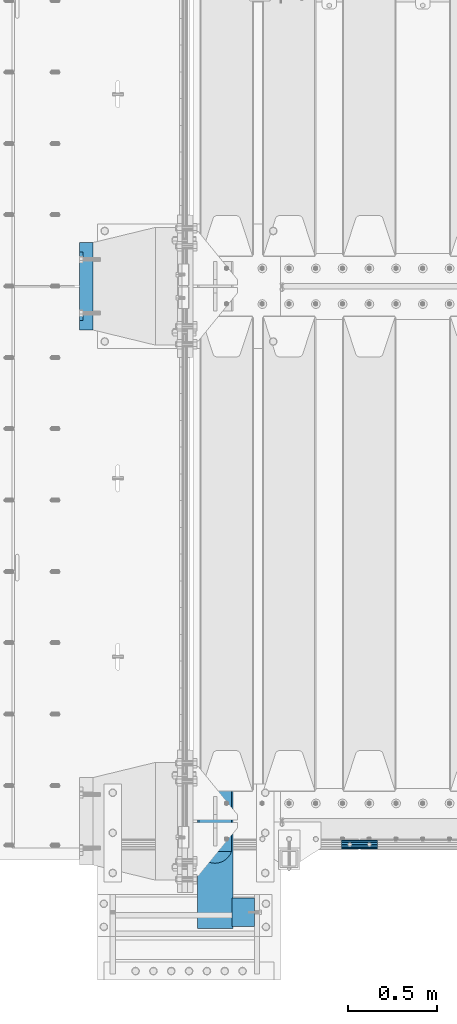
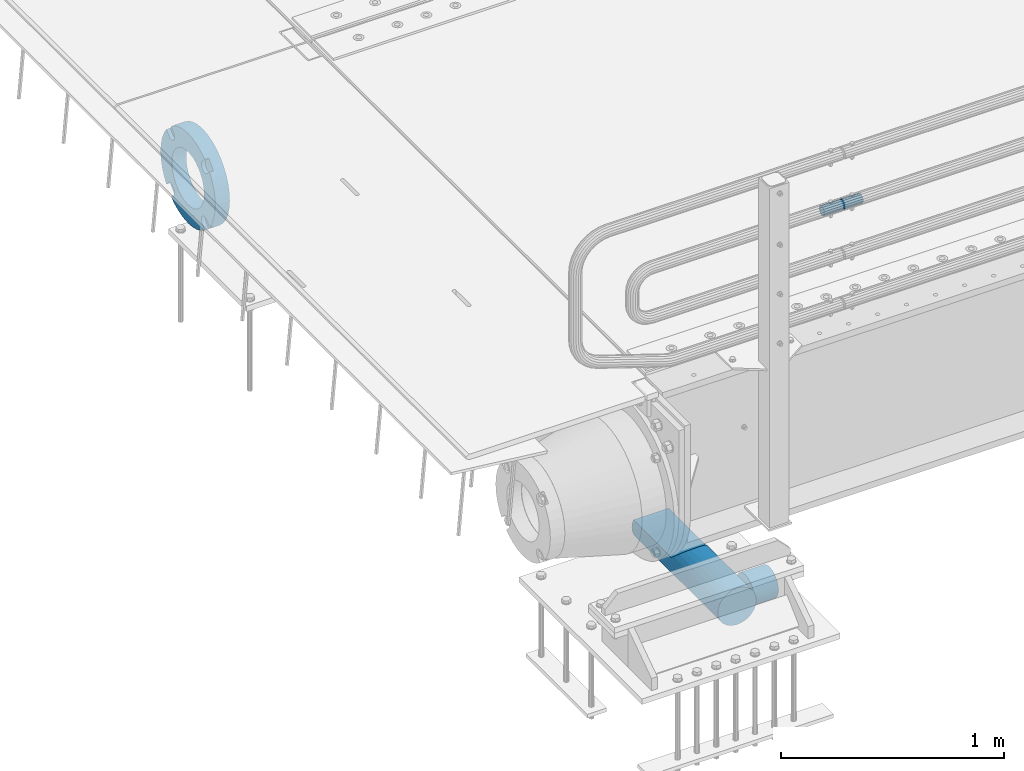
# One storey, part 139 of 242: 4 beams.
"""IFC2X3 building model written with IfcOpenShell, lengths in millimetres."""

from ifc_helpers import new_model, si_unit, frame, origin_with_axes, place, context, subcontext, project, spatial, faceted_brep, material, type_object, element, save


model = new_model("IFC2X3")

# Units and contexts
model_context = context("Model", 3, precision=1e-05, world=origin_with_axes())
body_context = subcontext(model_context, "Body", "Model", "MODEL_VIEW")
ifc_project = project(units=[si_unit("LENGTHUNIT", "METRE", prefix="MILLI"), si_unit("AREAUNIT", "SQUARE_METRE"), si_unit("VOLUMEUNIT", "CUBIC_METRE"), si_unit("MASSUNIT", "GRAM", prefix="KILO"), si_unit("TIMEUNIT", "SECOND"), si_unit("PLANEANGLEUNIT", "RADIAN"), si_unit("SOLIDANGLEUNIT", "STERADIAN"), si_unit("THERMODYNAMICTEMPERATUREUNIT", "DEGREE_CELSIUS"), si_unit("LUMINOUSINTENSITYUNIT", "LUMEN")], contexts=[model_context])

# Site, building, storey
site_placement = place(None, origin_with_axes())
site = spatial("IfcSite", under=ifc_project, at=site_placement, CompositionType="ELEMENT")
building_placement = place(site_placement, origin_with_axes())
building = spatial("IfcBuilding", under=site, at=building_placement, Name="Standard", CompositionType="ELEMENT")
storey_placement = place(building_placement, origin_with_axes())
storey = spatial("IfcBuildingStorey", under=building, at=storey_placement, Name="Undefined", CompositionType="ELEMENT", Elevation=0.0)

# Beams
ifc_material_1 = material()
beam_type_1 = type_object("IfcBeamType", PredefinedType="NOTDEFINED")
beam_1_placement = place(storey_placement, frame((-41605.0024970001, -24129.8499999996, 689.849999999726), z_axis=(0.0, 0.0, 1.0), x_axis=(1.0, 0.0, 0.0)))
element("IfcBeam", 1, at=beam_1_placement, inside=storey, type_object=beam_type_1, material=ifc_material_1, context=body_context, shape_type="Brep", body=[
    faceted_brep([(0.0, -21.9000000000015, 0.0), (0.0, -20.232961761998, 8.38076716879547), (200.0, -20.232961761998, 8.38076716879547), (200.0, -21.9000000000015, 0.0), (0.0, -15.4856385079838, 15.4856385079854), (200.0, -15.4856385079838, 15.4856385079854), (0.0, -8.38076716879368, 20.2329617619972), (200.0, -8.38076716879368, 20.2329617619972), (0.0, 0.0, 21.9), (200.0, 0.0, 21.9), (0.0, 8.38076716879368, 20.2329617619972), (200.0, 8.38076716879368, 20.2329617619972), (0.0, 15.4856385079838, 15.4856385079854), (200.0, 15.4856385079838, 15.4856385079854), (0.0, 20.232961761998, 8.38076716879547), (200.0, 20.232961761998, 8.38076716879547), (0.0, 21.9000000000015, 0.0), (200.0, 21.9000000000015, 0.0), (0.0, 20.232961761998, -8.38076716879547), (200.0, 20.232961761998, -8.38076716879547), (0.0, 15.4856385079838, -15.4856385079854), (200.0, 15.4856385079838, -15.4856385079854), (0.0, 8.38076716879368, -20.2329617619972), (200.0, 8.38076716879368, -20.2329617619972), (0.0, 0.0, -21.9), (200.0, 0.0, -21.9), (0.0, -8.38076716879368, -20.2329617619972), (200.0, -8.38076716879368, -20.2329617619972), (0.0, -15.4856385079838, -15.4856385079854), (200.0, -15.4856385079838, -15.4856385079854), (0.0, -20.232961761998, -8.38076716879547), (200.0, -20.232961761998, -8.38076716879547), (0.0, -25.5, 0.0), (0.0, -23.5589280790373, -9.7584275253098), (200.0, -23.5589280790373, -9.7584275253098), (200.0, -25.5, 0.0), (0.0, -18.0312229202573, -18.031222920257), (200.0, -18.0312229202573, -18.031222920257), (0.0, -9.75842752531025, -23.5589280790378), (200.0, -9.75842752531025, -23.5589280790378), (0.0, 0.0, -25.5), (200.0, 0.0, -25.5), (0.0, 9.75842752531025, -23.5589280790378), (200.0, 9.75842752531025, -23.5589280790378), (0.0, 18.0312229202573, -18.031222920257), (200.0, 18.0312229202573, -18.031222920257), (0.0, 23.5589280790373, -9.7584275253098), (200.0, 23.5589280790373, -9.7584275253098), (0.0, 25.5, 0.0), (200.0, 25.5, 0.0), (0.0, 23.5589280790373, 9.7584275253098), (200.0, 23.5589280790373, 9.7584275253098), (0.0, 18.0312229202573, 18.031222920257), (200.0, 18.0312229202573, 18.031222920257), (0.0, 9.75842752531025, 23.5589280790378), (200.0, 9.75842752531025, 23.5589280790378), (0.0, 0.0, 25.5), (200.0, 0.0, 25.5), (0.0, -9.75842752531025, 23.5589280790378), (200.0, -9.75842752531025, 23.5589280790378), (0.0, -18.0312229202573, 18.031222920257), (200.0, -18.0312229202573, 18.031222920257), (0.0, -23.5589280790373, 9.7584275253098), (200.0, -23.5589280790373, 9.7584275253098)], [[[0, 1, 2, 3]], [[1, 4, 5, 2]], [[4, 6, 7, 5]], [[6, 8, 9, 7]], [[8, 10, 11, 9]], [[10, 12, 13, 11]], [[12, 14, 15, 13]], [[14, 16, 17, 15]], [[16, 18, 19, 17]], [[18, 20, 21, 19]], [[20, 22, 23, 21]], [[22, 24, 25, 23]], [[24, 26, 27, 25]], [[26, 28, 29, 27]], [[28, 30, 31, 29]], [[30, 0, 3, 31]], [[32, 33, 34, 35]], [[33, 36, 37, 34]], [[36, 38, 39, 37]], [[38, 40, 41, 39]], [[40, 42, 43, 41]], [[42, 44, 45, 43]], [[44, 46, 47, 45]], [[46, 48, 49, 47]], [[48, 50, 51, 49]], [[50, 52, 53, 51]], [[52, 54, 55, 53]], [[54, 56, 57, 55]], [[56, 58, 59, 57]], [[58, 60, 61, 59]], [[60, 62, 63, 61]], [[62, 32, 35, 63]], [[37, 39, 41, 43, 45, 47, 49, 51, 53, 55, 57, 59, 61, 63, 35, 34], [5, 7, 9, 11, 13, 15, 17, 19, 21, 23, 25, 27, 29, 31, 3, 2]], [[62, 60, 58, 56, 54, 52, 50, 48, 46, 44, 42, 40, 38, 36, 33, 32], [30, 28, 26, 24, 22, 20, 18, 16, 14, 12, 10, 8, 6, 4, 1, 0]]]),
])
ifc_material_2 = material(Name="STEEL/S355N")
beam_type_2 = type_object("IfcBeamType", Name="D200", PredefinedType="NOTDEFINED")
beam_2_placement = place(storey_placement, frame((-42315.0, -24600.0, -938.0), z_axis=(0.0, 0.0, 1.0), x_axis=(0.0, 1.0, 0.0)))
element("IfcBeam", 2, at=beam_2_placement, inside=storey, type_object=beam_type_2, material=ifc_material_2, ObjectType="D200", context=body_context, shape_type="Brep", body=[
    faceted_brep([(417.294117647056, 86.6025403784442, 50.0), (395.365164344952, 70.7106781186521, 70.7106781186548), (378.538486658119, 50.0, 86.6025403784439), (367.960794863509, 25.88190451025, 96.5925826289068), (364.352941176468, 0.0, 100.0), (367.960794863509, -25.88190451025, 96.5925826289068), (378.538486658119, -50.0, 86.6025403784439), (395.365164344952, -70.7106781186521, 70.7106781186548), (417.294117647056, -86.6025403784442, 50.0), (430.0, -91.5731031269243, 38.0), (430.0, 91.5731031269243, 38.0), (770.0, -91.5731031269243, 37.9999999999994), (770.0, 91.5731031269243, 37.9999999999994), (0.0, -96.5925826289094, 25.8819045102521), (0.0, -86.6025403784442, 50.0), (0.0, -70.7106781186521, 70.7106781186548), (0.0, -50.0, 86.6025403784439), (0.0, -25.88190451025, 96.5925826289068), (0.0, 0.0, 100.0), (0.0, 25.88190451025, 96.5925826289068), (0.0, 50.0, 86.6025403784439), (0.0, 70.7106781186521, 70.7106781186548), (0.0, 86.6025403784442, 50.0), (0.0, 96.5925826289094, 25.8819045102521), (0.0, 100.0, 0.0), (0.0, 96.5925826289094, -25.8819045102521), (0.0, 86.6025403784442, -50.0), (0.0, 70.7106781186521, -70.7106781186548), (0.0, 50.0, -86.6025403784438), (0.0, 25.88190451025, -96.5925826289067), (0.0, 0.0, -100.0), (0.0, -25.88190451025, -96.5925826289069), (0.0, -50.0, -86.6025403784438), (0.0, -70.7106781186521, -70.7106781186548), (0.0, -86.6025403784442, -50.0), (0.0, -96.5925826289094, -25.8819045102522), (0.0, -100.0, 0.0), (770.0, 96.5925826289094, 25.8819045102521), (770.0, 100.0, 0.0), (770.0, 96.5925826289094, -25.8819045102521), (770.0, 86.6025403784442, -50.0), (770.0, 70.7106781186521, -70.7106781186548), (770.0, 50.0, -86.6025403784438), (770.0, 25.88190451025, -96.5925826289067), (770.0, 0.0, -100.0), (770.0, -25.88190451025, -96.5925826289069), (770.0, -50.0, -86.6025403784438), (770.0, -70.7106781186521, -70.7106781186548), (770.0, -86.6025403784442, -50.0), (770.0, -96.5925826289094, -25.8819045102522), (770.0, -100.0, 0.0), (770.0, -96.5925826289094, 25.8819045102521)], [[[0, 1, 2, 3, 4, 5, 6, 7, 8, 9, 10]], [[10, 9, 11, 12]], [[13, 14, 15, 16, 17, 18, 19, 20, 21, 22, 23, 24, 25, 26, 27, 28, 29, 30, 31, 32, 33, 34, 35, 36]], [[24, 23, 37, 38]], [[25, 24, 38, 39]], [[26, 25, 39, 40]], [[27, 26, 40, 41]], [[28, 27, 41, 42]], [[29, 28, 42, 43]], [[30, 29, 43, 44]], [[31, 30, 44, 45]], [[32, 31, 45, 46]], [[33, 32, 46, 47]], [[34, 33, 47, 48]], [[35, 34, 48, 49]], [[36, 35, 49, 50]], [[13, 36, 50, 51]], [[14, 13, 51, 11, 9, 8]], [[15, 14, 8, 7]], [[16, 15, 7, 6]], [[17, 16, 6, 5]], [[18, 17, 5, 4]], [[19, 18, 4, 3]], [[20, 19, 3, 2]], [[21, 20, 2, 1]], [[22, 21, 1, 0]], [[37, 23, 22, 0, 10, 12]], [[51, 50, 49, 48, 47, 46, 45, 44, 43, 42, 41, 40, 39, 38, 37, 12, 11]]]),
])
ifc_material_3 = material(Name="SCN-500-E2")
beam_type_3 = type_object("IfcBeamType", PredefinedType="NOTDEFINED")
beam_3_placement = place(storey_placement, frame((-43000.0, -20999.9999985338, -515.0), z_axis=(0.0, 0.0, 1.0), x_axis=(-1.0, 0.0, 0.0)))
element("IfcBeam", 3, at=beam_3_placement, inside=storey, type_object=beam_type_3, material=ifc_material_3, context=body_context, shape_type="Brep", body=[
    faceted_brep([(75.0, 192.717024793295, -150.290616455868), (75.0, 171.473395903973, -129.046987566545), (55.0, 171.473395903973, -129.046987566545), (55.0, 192.717024793295, -150.290616455868), (75.0, 167.467485558907, -125.685629673471), (55.0, 167.467485558907, -125.685629673471), (75.0, 162.938740320598, -123.070957391042), (55.0, 162.938740320598, -123.070957391042), (75.0, 158.024763821453, -121.282416213469), (55.0, 158.024763821453, -121.282416213469), (75.0, 152.874864750807, -120.374350059389), (55.0, 152.874864750807, -120.374350059389), (75.0, 147.645520185946, -120.374350059389), (55.0, 147.645520185946, -120.374350059389), (75.0, 142.4956211153, -121.282416213469), (55.0, 142.4956211153, -121.282416213469), (75.0, 137.581644616155, -123.070957391042), (55.0, 137.581644616155, -123.070957391042), (75.0, 133.052899377846, -125.685629673471), (55.0, 133.052899377846, -125.685629673471), (75.0, 129.04698903278, -129.046987566545), (55.0, 129.04698903278, -129.046987566545), (75.0, 125.685631139706, -133.05289791161), (55.0, 125.685631139706, -133.05289791161), (75.0, 123.070958857279, -137.58164314992), (55.0, 123.070958857279, -137.58164314992), (75.0, 121.282417679704, -142.495619649066), (55.0, 121.282417679704, -142.495619649066), (75.0, 120.374351525625, -147.645518719712), (55.0, 120.374351525625, -147.645518719712), (75.0, 120.374351525625, -152.874863284571), (55.0, 120.374351525625, -152.874863284571), (75.0, 121.282417679704, -158.024762355217), (55.0, 121.282417679704, -158.024762355217), (75.0, 123.070958857279, -162.938738854362), (55.0, 123.070958857279, -162.938738854362), (75.0, 125.685631139706, -167.467484092673), (55.0, 125.685631139706, -167.467484092673), (75.0, 129.04698903278, -171.473394437738), (55.0, 129.04698903278, -171.473394437738), (55.0, 150.290618180639, -192.717023585596), (75.0, 150.290618180639, -192.717023585596), (55.0, 157.482964373201, -187.68088856415), (55.0, 187.680888564151, -157.482964373202), (75.0, -192.717023585596, 150.290618180643), (75.0, -171.4733929715, 129.046987566545), (55.0, -171.4733929715, 129.046987566545), (55.0, -192.717023585599, 150.290618180643), (75.0, -167.467482626435, 125.685629673472), (55.0, -167.467482626435, 125.685629673472), (75.0, -162.938737388125, 123.070957391042), (55.0, -162.938737388125, 123.070957391042), (75.0, -158.02476088898, 121.282416213469), (55.0, -158.02476088898, 121.282416213469), (75.0, -152.874861818334, 120.374350059389), (55.0, -152.874861818334, 120.374350059389), (75.0, -147.645517253473, 120.374350059389), (55.0, -147.645517253473, 120.374350059389), (75.0, -142.495618182827, 121.282416213469), (55.0, -142.495618182827, 121.282416213469), (75.0, -137.581641683682, 123.070957391042), (55.0, -137.581641683682, 123.070957391042), (75.0, -133.052896445373, 125.685629673472), (55.0, -133.052896445373, 125.685629673472), (75.0, -129.046986100308, 129.046987566545), (55.0, -129.046986100308, 129.046987566545), (75.0, -125.685628207233, 133.05289791161), (55.0, -125.685628207233, 133.05289791161), (75.0, -123.070955924806, 137.58164314992), (55.0, -123.070955924806, 137.58164314992), (75.0, -121.282414747231, 142.495619649066), (55.0, -121.282414747231, 142.495619649066), (75.0, -120.374348593152, 147.645518719712), (55.0, -120.374348593152, 147.645518719712), (75.0, -120.374348593152, 152.874863284571), (55.0, -120.374348593152, 152.874863284571), (75.0, -121.282414747231, 158.024762355217), (55.0, -121.282414747231, 158.024762355217), (75.0, -123.070955924806, 162.938738854362), (55.0, -123.070955924806, 162.938738854362), (75.0, -125.685628207233, 167.467484092673), (55.0, -125.685628207233, 167.467484092673), (75.0, -129.046986100308, 171.473394437738), (55.0, -129.046986100308, 171.473394437738), (55.0, -150.290616455866, 192.717024793295), (75.0, -150.290616455866, 192.717024793295), (75.0, 150.290618180639, 192.717023585597), (75.0, 129.04698903278, 171.473394437739), (55.0, 129.04698903278, 171.473394437739), (55.0, 150.290618180639, 192.717023585598), (75.0, 125.685631139706, 167.467484092674), (55.0, 125.685631139706, 167.467484092674), (75.0, 123.070958857279, 162.938738854364), (55.0, 123.070958857279, 162.938738854364), (75.0, 121.282417679704, 158.024762355218), (55.0, 121.282417679704, 158.024762355218), (75.0, 120.374351525625, 152.874863284572), (55.0, 120.374351525625, 152.874863284572), (75.0, 120.374351525625, 147.645518719713), (55.0, 120.374351525625, 147.645518719713), (75.0, 121.282417679704, 142.495619649067), (55.0, 121.282417679704, 142.495619649067), (75.0, 123.070958857279, 137.581643149922), (55.0, 123.070958857279, 137.581643149922), (75.0, 125.685631139706, 133.052897911611), (55.0, 125.685631139706, 133.052897911611), (75.0, 129.04698903278, 129.046987566546), (55.0, 129.04698903278, 129.046987566546), (75.0, 133.052899377846, 125.685629673473), (55.0, 133.052899377846, 125.685629673473), (75.0, 137.581644616155, 123.070957391043), (55.0, 137.581644616155, 123.070957391043), (75.0, 142.4956211153, 121.282416213471), (55.0, 142.4956211153, 121.282416213471), (75.0, 147.645520185946, 120.37435005939), (55.0, 147.645520185946, 120.37435005939), (75.0, 152.874864750807, 120.37435005939), (55.0, 152.874864750807, 120.37435005939), (75.0, 158.024763821453, 121.282416213471), (55.0, 158.024763821453, 121.282416213471), (75.0, 162.938740320598, 123.070957391043), (55.0, 162.938740320598, 123.070957391043), (75.0, 167.467485558907, 125.685629673473), (55.0, 167.467485558907, 125.685629673473), (75.0, 171.473395903973, 129.046987566546), (55.0, 171.473395903973, 129.046987566546), (55.0, 192.717024793295, 150.290616455869), (75.0, 192.717024793295, 150.290616455868), (0.0, 212.176223927188, -122.5), (0.0, 230.224692092546, -83.7949351147888), (75.0, 230.224692092546, -83.7949351147888), (75.0, 212.176223927188, -122.5), (0.0, 241.277899487992, -42.5438035283978), (75.0, 241.277899487992, -42.5438035283978), (0.0, 245.0, 0.0), (75.0, 245.0, 0.0), (0.0, 241.277899487992, 42.543803528398), (75.0, 241.277899487992, 42.543803528398), (0.0, 230.224692092546, 83.7949351147889), (75.0, 230.224692092546, 83.7949351147889), (0.0, 212.176223927188, 122.5), (75.0, 212.176223927188, 122.5), (0.0, 187.680888564151, 157.482964373202), (55.0, 187.680888564151, 157.482964373202), (0.0, 157.482964373201, 187.68088856415), (55.0, 157.482964373201, 187.68088856415), (0.0, 122.5, 212.176223927187), (75.0, 122.5, 212.176223927187), (0.0, 83.7949351147872, 230.224692092548), (75.0, 83.7949351147872, 230.224692092548), (0.0, 42.5438035283987, 241.277899487991), (75.0, 42.5438035283987, 241.277899487991), (0.0, 0.0, 245.0), (75.0, 0.0, 245.0), (0.0, -42.5438035283987, 241.277899487991), (75.0, -42.5438035283987, 241.277899487991), (0.0, -83.7949351147872, 230.224692092548), (75.0, -83.7949351147872, 230.224692092548), (0.0, -122.5, 212.176223927187), (75.0, -122.5, 212.176223927187), (0.0, -157.482964373201, 187.68088856415), (55.0, -157.482964373201, 187.68088856415), (0.0, -187.680888564151, 157.482964373202), (55.0, -187.680888564151, 157.482964373202), (0.0, -212.176223927188, 122.5), (75.0, -212.176223927188, 122.5), (0.0, -230.224692092546, 83.7949351147888), (75.0, -230.224692092546, 83.7949351147888), (0.0, -241.277899487992, 42.5438035283979), (75.0, -241.277899487992, 42.5438035283979), (0.0, -245.0, 0.0), (75.0, -245.0, 0.0), (0.0, -187.680888564151, -157.482964373202), (0.0, -157.482964373201, -187.68088856415), (55.0, -157.482964373201, -187.68088856415), (55.0, -187.680888564151, -157.482964373202), (0.0, 83.7949351147872, -230.224692092547), (0.0, 122.5, -212.176223927187), (75.0, 122.5, -212.176223927187), (75.0, 83.7949351147872, -230.224692092547), (0.0, 42.5438035283987, -241.277899487991), (75.0, 42.5438035283987, -241.277899487991), (0.0, 0.0, -245.0), (75.0, 0.0, -245.0), (0.0, -42.5438035283987, -241.277899487991), (75.0, -42.5438035283987, -241.277899487991), (0.0, -83.7949351147872, -230.224692092548), (75.0, -83.7949351147872, -230.224692092548), (0.0, -122.5, -212.176223927187), (75.0, -122.5, -212.176223927187), (75.0, -150.290616455863, -192.717024793296), (55.0, -150.290616455863, -192.717024793296), (55.0, -129.046986100308, -171.473394437739), (55.0, -125.685628207233, -167.467484092674), (55.0, -123.070955924806, -162.938738854364), (55.0, -121.282414747231, -158.024762355218), (55.0, -120.374348593152, -152.874863284572), (55.0, -120.374348593152, -147.645518719713), (55.0, -121.282414747231, -142.495619649067), (55.0, -123.070955924806, -137.581643149922), (55.0, -125.685628207233, -133.052897911611), (55.0, -129.046986100308, -129.046987566546), (55.0, -133.052896445373, -125.685629673473), (55.0, -137.581641683682, -123.070957391043), (55.0, -142.495618182827, -121.282416213471), (55.0, -147.645517253473, -120.37435005939), (55.0, -152.874861818334, -120.37435005939), (55.0, -158.02476088898, -121.282416213471), (55.0, -162.938737388125, -123.070957391043), (55.0, -167.467482626435, -125.685629673473), (55.0, -171.4733929715, -129.046987566546), (55.0, -192.717023585596, -150.290618180642), (75.0, -129.046986100308, -171.473394437739), (75.0, -125.685628207233, -167.467484092674), (75.0, -123.070955924806, -162.938738854364), (75.0, -121.282414747231, -158.024762355218), (75.0, -120.374348593152, -152.874863284572), (75.0, -120.374348593152, -147.645518719713), (75.0, -121.282414747231, -142.495619649067), (75.0, -123.070955924806, -137.581643149922), (75.0, -125.685628207233, -133.052897911611), (75.0, -129.046986100308, -129.046987566546), (75.0, -133.052896445373, -125.685629673473), (75.0, -137.581641683682, -123.070957391043), (75.0, -142.495618182827, -121.282416213471), (75.0, -147.645517253473, -120.37435005939), (75.0, -152.874861818334, -120.37435005939), (75.0, -158.02476088898, -121.282416213471), (75.0, -162.938737388125, -123.070957391043), (75.0, -167.467482626435, -125.685629673473), (75.0, -171.4733929715, -129.046987566546), (75.0, -192.717023585596, -150.290618180642), (75.0, -212.176223927188, -122.5), (0.0, -212.176223927188, -122.5), (0.0, -230.224692092546, -83.794935114789), (75.0, -230.224692092546, -83.794935114789), (0.0, -241.277899487992, -42.5438035283979), (75.0, -241.277899487992, -42.5438035283979), (0.0, 187.680888564151, -157.482964373202), (0.0, 157.482964373201, -187.68088856415), (0.0, -142.797124186771, -25.1789857617049), (0.0, -136.255430013956, -49.592920782222), (0.0, -125.573683548744, -72.5), (0.0, -111.076444252252, -93.2042034045483), (0.0, -93.204203404548, -111.076444252252), (0.0, -72.5, -125.573683548744), (0.0, -49.5929207822228, -136.255430013957), (0.0, -25.1789857617041, -142.79712418677), (0.0, 0.0, -145.0), (0.0, 25.1789857617041, -142.79712418677), (0.0, 49.5929207822228, -136.255430013957), (0.0, 72.5, -125.573683548744), (0.0, 93.204203404548, -111.076444252252), (0.0, 111.076444252252, -93.2042034045483), (0.0, 125.573683548744, -72.5), (0.0, 136.255430013956, -49.592920782222), (0.0, 142.797124186771, -25.178985761705), (0.0, 145.0, 0.0), (0.0, 142.797124186771, 25.1789857617048), (0.0, 136.255430013956, 49.5929207822219), (0.0, 125.573683548744, 72.4999999999999), (0.0, 111.076444252252, 93.2042034045482), (0.0, 93.204203404548, 111.076444252252), (0.0, 72.5, 125.573683548744), (0.0, 49.5929207822228, 136.255430013957), (0.0, 25.1789857617041, 142.79712418677), (0.0, 0.0, 145.0), (0.0, -25.1789857617041, 142.79712418677), (0.0, -49.5929207822228, 136.255430013957), (0.0, -72.5, 125.573683548744), (0.0, -93.204203404548, 111.076444252252), (0.0, -111.076444252252, 93.2042034045483), (0.0, -125.573683548744, 72.5000000000001), (0.0, -136.255430013956, 49.5929207822221), (0.0, -142.797124186771, 25.1789857617049), (0.0, -145.0, 0.0), (75.0, -145.0, 0.0), (75.0, -142.797124186771, -25.1789857617049), (75.0, -136.255430013956, -49.592920782222), (75.0, -125.573683548744, -72.5), (75.0, -111.076444252252, -93.2042034045483), (75.0, -93.204203404548, -111.076444252252), (75.0, -72.5, -125.573683548744), (75.0, -49.5929207822228, -136.255430013957), (75.0, -25.1789857617041, -142.79712418677), (75.0, 0.0, -145.0), (75.0, 25.1789857617041, -142.79712418677), (75.0, 49.5929207822228, -136.255430013957), (75.0, 72.5, -125.573683548744), (75.0, 93.204203404548, -111.076444252252), (75.0, 111.076444252252, -93.2042034045483), (75.0, 125.573683548744, -72.5), (75.0, 136.255430013956, -49.592920782222), (75.0, 142.797124186771, -25.178985761705), (75.0, 145.0, 0.0), (75.0, 142.797124186771, 25.1789857617048), (75.0, 136.255430013956, 49.5929207822219), (75.0, 125.573683548744, 72.4999999999999), (75.0, 111.076444252252, 93.2042034045482), (75.0, 93.204203404548, 111.076444252252), (75.0, 72.5, 125.573683548744), (75.0, 49.5929207822228, 136.255430013957), (75.0, 25.1789857617041, 142.79712418677), (75.0, 0.0, 145.0), (75.0, -25.1789857617041, 142.79712418677), (75.0, -49.5929207822228, 136.255430013957), (75.0, -72.5, 125.573683548744), (75.0, -93.204203404548, 111.076444252252), (75.0, -111.076444252252, 93.2042034045483), (75.0, -125.573683548744, 72.5000000000001), (75.0, -136.255430013956, 49.5929207822221), (75.0, -142.797124186771, 25.1789857617049)], [[[0, 1, 2, 3]], [[4, 5, 2, 1]], [[6, 7, 5, 4]], [[8, 9, 7, 6]], [[10, 11, 9, 8]], [[12, 13, 11, 10]], [[14, 15, 13, 12]], [[16, 17, 15, 14]], [[18, 19, 17, 16]], [[20, 21, 19, 18]], [[22, 23, 21, 20]], [[24, 25, 23, 22]], [[26, 27, 25, 24]], [[28, 29, 27, 26]], [[30, 31, 29, 28]], [[32, 33, 31, 30]], [[34, 35, 33, 32]], [[36, 37, 35, 34]], [[38, 39, 37, 36]], [[40, 39, 38, 41]], [[42, 43, 3, 2, 5, 7, 9, 11, 13, 15, 17, 19, 21, 23, 25, 27, 29, 31, 33, 35, 37, 39, 40]], [[44, 45, 46, 47]], [[48, 49, 46, 45]], [[50, 51, 49, 48]], [[52, 53, 51, 50]], [[54, 55, 53, 52]], [[56, 57, 55, 54]], [[58, 59, 57, 56]], [[60, 61, 59, 58]], [[62, 63, 61, 60]], [[64, 65, 63, 62]], [[66, 67, 65, 64]], [[68, 69, 67, 66]], [[70, 71, 69, 68]], [[72, 73, 71, 70]], [[74, 75, 73, 72]], [[76, 77, 75, 74]], [[78, 79, 77, 76]], [[80, 81, 79, 78]], [[82, 83, 81, 80]], [[84, 83, 82, 85]], [[86, 87, 88, 89]], [[90, 91, 88, 87]], [[92, 93, 91, 90]], [[94, 95, 93, 92]], [[96, 97, 95, 94]], [[98, 99, 97, 96]], [[100, 101, 99, 98]], [[102, 103, 101, 100]], [[104, 105, 103, 102]], [[106, 107, 105, 104]], [[108, 109, 107, 106]], [[110, 111, 109, 108]], [[112, 113, 111, 110]], [[114, 115, 113, 112]], [[116, 117, 115, 114]], [[118, 119, 117, 116]], [[120, 121, 119, 118]], [[122, 123, 121, 120]], [[124, 125, 123, 122]], [[126, 125, 124, 127]], [[128, 129, 130, 131]], [[129, 132, 133, 130]], [[132, 134, 135, 133]], [[134, 136, 137, 135]], [[136, 138, 139, 137]], [[138, 140, 141, 139]], [[127, 141, 140, 142, 143, 126]], [[142, 144, 145, 143]], [[89, 88, 91, 93, 95, 97, 99, 101, 103, 105, 107, 109, 111, 113, 115, 117, 119, 121, 123, 125, 126, 143, 145]], [[144, 146, 147, 86, 89, 145]], [[146, 148, 149, 147]], [[148, 150, 151, 149]], [[150, 152, 153, 151]], [[152, 154, 155, 153]], [[154, 156, 157, 155]], [[156, 158, 159, 157]], [[85, 159, 158, 160, 161, 84]], [[160, 162, 163, 161]], [[47, 46, 49, 51, 53, 55, 57, 59, 61, 63, 65, 67, 69, 71, 73, 75, 77, 79, 81, 83, 84, 161, 163]], [[162, 164, 165, 44, 47, 163]], [[164, 166, 167, 165]], [[166, 168, 169, 167]], [[168, 170, 171, 169]], [[172, 173, 174, 175]], [[176, 177, 178, 179]], [[180, 176, 179, 181]], [[182, 180, 181, 183]], [[184, 182, 183, 185]], [[186, 184, 185, 187]], [[188, 186, 187, 189]], [[173, 188, 189, 190, 191, 174]], [[175, 174, 191, 192, 193, 194, 195, 196, 197, 198, 199, 200, 201, 202, 203, 204, 205, 206, 207, 208, 209, 210, 211]], [[190, 212, 192, 191]], [[213, 193, 192, 212]], [[214, 194, 193, 213]], [[215, 195, 194, 214]], [[216, 196, 195, 215]], [[217, 197, 196, 216]], [[218, 198, 197, 217]], [[219, 199, 198, 218]], [[220, 200, 199, 219]], [[221, 201, 200, 220]], [[222, 202, 201, 221]], [[223, 203, 202, 222]], [[224, 204, 203, 223]], [[225, 205, 204, 224]], [[226, 206, 205, 225]], [[227, 207, 206, 226]], [[228, 208, 207, 227]], [[229, 209, 208, 228]], [[230, 210, 209, 229]], [[211, 210, 230, 231]], [[232, 233, 172, 175, 211, 231]], [[234, 233, 232, 235]], [[236, 234, 235, 237]], [[170, 236, 237, 171]], [[168, 166, 164, 162, 160, 158, 156, 154, 152, 150, 148, 146, 144, 142, 140, 138, 136, 134, 132, 129, 128, 238, 239, 177, 176, 180, 182, 184, 186, 188, 173, 172, 233, 234, 236, 170], [240, 241, 242, 243, 244, 245, 246, 247, 248, 249, 250, 251, 252, 253, 254, 255, 256, 257, 258, 259, 260, 261, 262, 263, 264, 265, 266, 267, 268, 269, 270, 271, 272, 273, 274, 275]], [[240, 275, 276, 277]], [[241, 240, 277, 278]], [[242, 241, 278, 279]], [[243, 242, 279, 280]], [[244, 243, 280, 281]], [[245, 244, 281, 282]], [[246, 245, 282, 283]], [[247, 246, 283, 284]], [[248, 247, 284, 285]], [[249, 248, 285, 286]], [[250, 249, 286, 287]], [[251, 250, 287, 288]], [[252, 251, 288, 289]], [[253, 252, 289, 290]], [[254, 253, 290, 291]], [[255, 254, 291, 292]], [[256, 255, 292, 293]], [[257, 256, 293, 294]], [[258, 257, 294, 295]], [[259, 258, 295, 296]], [[260, 259, 296, 297]], [[261, 260, 297, 298]], [[262, 261, 298, 299]], [[263, 262, 299, 300]], [[264, 263, 300, 301]], [[265, 264, 301, 302]], [[266, 265, 302, 303]], [[267, 266, 303, 304]], [[268, 267, 304, 305]], [[269, 268, 305, 306]], [[270, 269, 306, 307]], [[271, 270, 307, 308]], [[272, 271, 308, 309]], [[273, 272, 309, 310]], [[274, 273, 310, 311]], [[275, 274, 311, 276]], [[24, 22, 20, 18, 16, 14, 12, 10, 8, 6, 4, 1, 0, 131, 130, 133, 135, 137, 139, 141, 127, 124, 122, 120, 118, 116, 114, 112, 110, 108, 106, 104, 102, 100, 98, 96, 94, 92, 90, 87, 86, 147, 149, 151, 153, 155, 157, 159, 85, 82, 80, 78, 76, 74, 72, 70, 68, 66, 64, 62, 60, 58, 56, 54, 52, 50, 48, 45, 44, 165, 167, 169, 171, 237, 235, 232, 231, 230, 229, 228, 227, 226, 225, 224, 223, 222, 221, 220, 219, 218, 217, 216, 215, 214, 213, 212, 190, 189, 187, 185, 183, 181, 179, 178, 41, 38, 36, 34, 32, 30, 28, 26], [310, 309, 308, 307, 306, 305, 304, 303, 302, 301, 300, 299, 298, 297, 296, 295, 294, 293, 292, 291, 290, 289, 288, 287, 286, 285, 284, 283, 282, 281, 280, 279, 278, 277, 276, 311]], [[238, 128, 131, 0, 3, 43]], [[239, 238, 43, 42]], [[178, 177, 239, 42, 40, 41]]]),
])
ifc_material_4 = material()
beam_type_4 = type_object("IfcBeamType", PredefinedType="NOTDEFINED")
beam_4_placement = place(storey_placement, frame((-42219.9999999977, -24509.9999999973, -933.000000000004), z_axis=(0.0, 0.0, -1.0), x_axis=(1.0, 0.0, 0.0)))
element("IfcBeam", 4, at=beam_4_placement, inside=storey, type_object=beam_type_4, material=ifc_material_4, context=body_context, shape_type="Brep", body=[
    faceted_brep([(0.0, -80.0000000000036, 0.0), (0.0, -77.2740661031312, -20.7055236082015), (125.0, -77.2740661031239, -20.7055236082017), (125.0, -80.0, 0.0), (-9.09494701772928e-13, -69.2820323027554, -40.0), (125.0, -69.2820323027554, -40.0), (-1.81898940354586e-12, -56.5685424949297, -56.5685424949224), (125.0, -56.5685424949224, -56.5685424949238), (0.0, -40.0000000000036, -69.2820323027554), (125.0, -40.0, -69.2820323027552), (-9.09494701772928e-13, -20.7055236082015, -77.2740661031239), (125.0, -20.7055236082015, -77.2740661031255), (-9.09494701772928e-13, -3.63797880709171e-12, -80.0), (125.0, 0.0, -80.0), (0.0, 20.7055236081978, -77.2740661031239), (125.0, 20.7055236082015, -77.2740661031255), (-9.09494701772928e-13, 39.9999999999927, -69.2820323027554), (125.0, 40.0, -69.2820323027551), (0.0, 56.5685424949188, -56.5685424949224), (125.0, 56.5685424949224, -56.5685424949238), (-9.09494701772928e-13, 69.2820323027518, -40.0), (125.0, 69.2820323027554, -40.0), (-1.81898940354586e-12, 77.2740661031203, -20.7055236082015), (125.0, 77.2740661031239, -20.7055236082016), (-1.81898940354586e-12, 79.9999999999964, 0.0), (125.0, 80.0, 0.0), (-1.81898940354586e-12, 77.2740661031203, 20.7055236082015), (125.0, 77.2740661031239, 20.7055236082017), (-9.09494701772928e-13, 69.2820323027518, 40.0), (125.0, 69.2820323027554, 40.0), (0.0, 56.5685424949188, 56.5685424949224), (125.0, 56.5685424949224, 56.5685424949238), (-9.09494701772928e-13, 39.9999999999927, 69.2820323027554), (125.0, 40.0, 69.2820323027551), (0.0, 20.7055236081978, 77.2740661031239), (125.0, 20.7055236082015, 77.2740661031255), (-9.09494701772928e-13, -3.63797880709171e-12, 80.0), (125.0, 0.0, 80.0), (-9.09494701772928e-13, -20.7055236082015, 77.2740661031239), (125.0, -20.7055236082015, 77.2740661031255), (0.0, -40.0000000000036, 69.2820323027554), (125.0, -40.0, 69.2820323027551), (-1.81898940354586e-12, -56.5685424949297, 56.5685424949224), (125.0, -56.5685424949224, 56.5685424949238), (-9.09494701772928e-13, -69.2820323027554, 40.0), (125.0, -69.2820323027554, 40.0), (0.0, -77.2740661031312, 20.7055236082015), (125.0, -77.2740661031239, 20.7055236082017)], [[[0, 1, 2, 3]], [[1, 4, 5, 2]], [[4, 6, 7, 5]], [[6, 8, 9, 7]], [[8, 10, 11, 9]], [[10, 12, 13, 11]], [[12, 14, 15, 13]], [[14, 16, 17, 15]], [[16, 18, 19, 17]], [[18, 20, 21, 19]], [[20, 22, 23, 21]], [[22, 24, 25, 23]], [[24, 26, 27, 25]], [[26, 28, 29, 27]], [[28, 30, 31, 29]], [[30, 32, 33, 31]], [[32, 34, 35, 33]], [[34, 36, 37, 35]], [[36, 38, 39, 37]], [[38, 40, 41, 39]], [[40, 42, 43, 41]], [[42, 44, 45, 43]], [[44, 46, 47, 45]], [[46, 0, 3, 47]], [[5, 7, 9, 11, 13, 15, 17, 19, 21, 23, 25, 27, 29, 31, 33, 35, 37, 39, 41, 43, 45, 47, 3, 2]], [[46, 44, 42, 40, 38, 36, 34, 32, 30, 28, 26, 24, 22, 20, 18, 16, 14, 12, 10, 8, 6, 4, 1, 0]]]),
])

save(model, "model.ifc")
